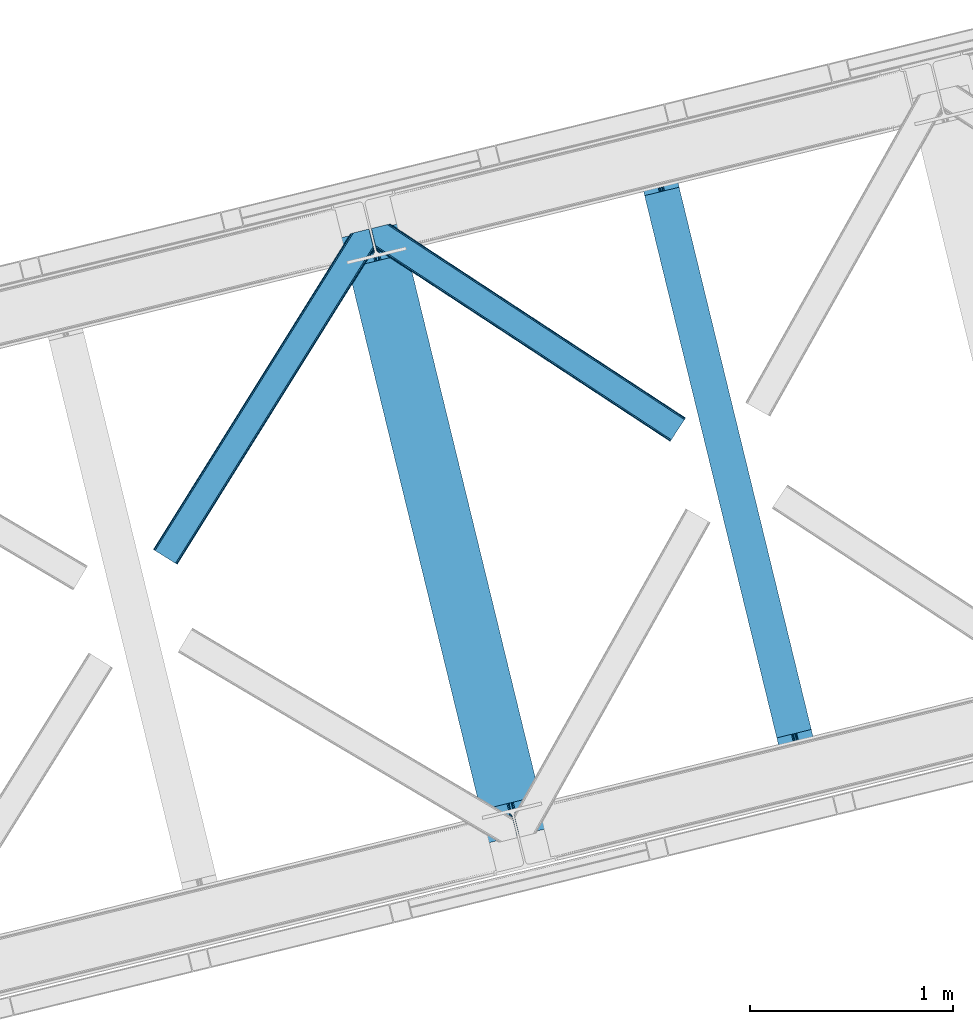
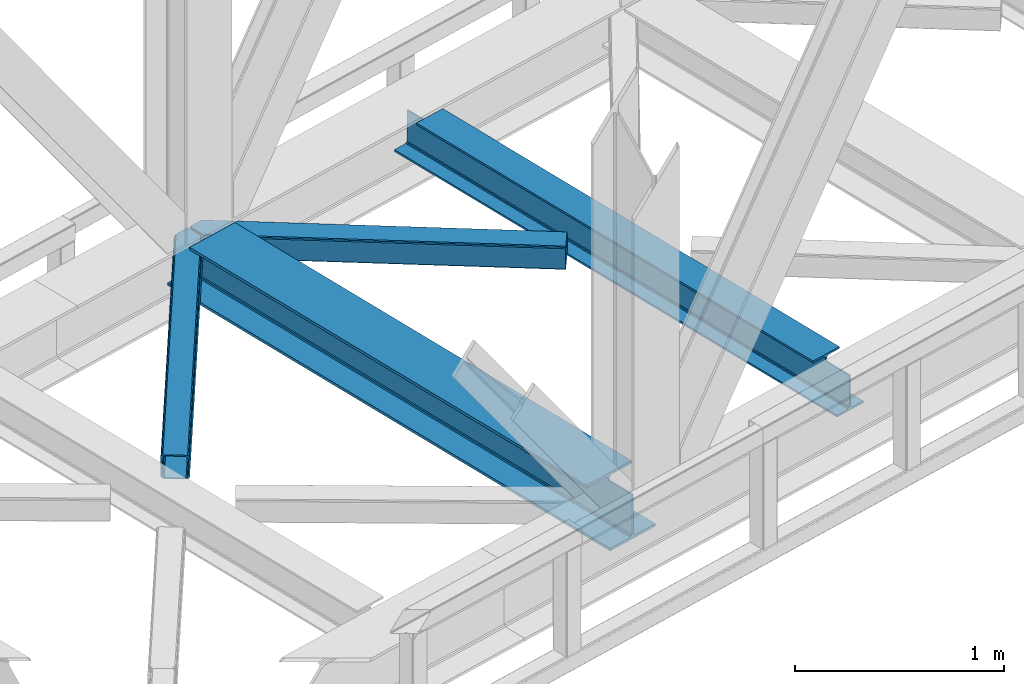
# One storey, part 77 of 92: 2 beams, 2 members.
"""IFC4 building model written with IfcOpenShell, lengths in millimetres."""

from ifc_helpers import new_model, entity, si_unit, converted_unit, derived_unit, direction, frame, origin, place, context, subcontext, project, spatial, triangles, polygons, material, type_object, element, save


model = new_model("IFC4")

# Units and contexts
model_context = context("Model", 3, precision=0.01, world=origin(), true_north=direction((6.12303176911189e-17, 1.0)))
plan_context = context("Plan", 3, precision=0.01, world=origin(), true_north=direction((6.12303176911189e-17, 1.0)))
body_context = subcontext(model_context, "Body", "Model", "MODEL_VIEW")
ifc_project = project(units=[si_unit("LENGTHUNIT", "METRE", prefix="MILLI"), si_unit("AREAUNIT", "SQUARE_METRE"), si_unit("VOLUMEUNIT", "CUBIC_METRE"), converted_unit("PLANEANGLEUNIT", "DEGREE", entity("IfcRatioMeasure", 0.0174532925199433), si_unit("PLANEANGLEUNIT", "RADIAN"), dimensions=[0, 0, 0, 0, 0, 0, 0]), si_unit("MASSUNIT", "GRAM", prefix="KILO"), derived_unit("MASSDENSITYUNIT", [(si_unit("MASSUNIT", "GRAM", prefix="KILO"), 1), (si_unit("LENGTHUNIT", "METRE"), -3)]), derived_unit("MOMENTOFINERTIAUNIT", [(si_unit("LENGTHUNIT", "METRE"), 4)]), si_unit("TIMEUNIT", "SECOND"), si_unit("FREQUENCYUNIT", "HERTZ"), si_unit("THERMODYNAMICTEMPERATUREUNIT", "DEGREE_CELSIUS"), derived_unit("THERMALTRANSMITTANCEUNIT", [(si_unit("MASSUNIT", "GRAM", prefix="KILO"), 1), (si_unit("THERMODYNAMICTEMPERATUREUNIT", "KELVIN"), -1), (si_unit("TIMEUNIT", "SECOND"), -3)]), derived_unit("VOLUMETRICFLOWRATEUNIT", [(si_unit("LENGTHUNIT", "METRE"), 3), (si_unit("TIMEUNIT", "SECOND"), -1)]), derived_unit("MASSFLOWRATEUNIT", [(si_unit("MASSUNIT", "GRAM", prefix="KILO"), 1), (si_unit("TIMEUNIT", "SECOND"), -1)]), derived_unit("ROTATIONALFREQUENCYUNIT", [(si_unit("TIMEUNIT", "SECOND"), -1)]), si_unit("ELECTRICCURRENTUNIT", "AMPERE"), si_unit("ELECTRICVOLTAGEUNIT", "VOLT"), si_unit("POWERUNIT", "WATT"), si_unit("FORCEUNIT", "NEWTON", prefix="KILO"), si_unit("ILLUMINANCEUNIT", "LUX"), si_unit("LUMINOUSFLUXUNIT", "LUMEN"), si_unit("LUMINOUSINTENSITYUNIT", "CANDELA"), derived_unit("USERDEFINED", [(si_unit("MASSUNIT", "GRAM", prefix="KILO"), -1), (si_unit("LENGTHUNIT", "METRE"), -2), (si_unit("TIMEUNIT", "SECOND"), 3), (si_unit("LUMINOUSFLUXUNIT", "LUMEN"), 1)]), derived_unit("LINEARVELOCITYUNIT", [(si_unit("LENGTHUNIT", "METRE"), 1), (si_unit("TIMEUNIT", "SECOND"), -1)]), si_unit("PRESSUREUNIT", "PASCAL"), derived_unit("USERDEFINED", [(si_unit("LENGTHUNIT", "METRE"), -2), (si_unit("MASSUNIT", "GRAM", prefix="KILO"), 1), (si_unit("TIMEUNIT", "SECOND"), -2)]), derived_unit("LINEARFORCEUNIT", [(si_unit("MASSUNIT", "GRAM", prefix="KILO"), 1), (si_unit("LENGTHUNIT", "METRE"), 1), (si_unit("TIMEUNIT", "SECOND"), -2), (si_unit("LENGTHUNIT", "METRE"), -1)]), derived_unit("PLANARFORCEUNIT", [(si_unit("MASSUNIT", "GRAM", prefix="KILO"), 1), (si_unit("LENGTHUNIT", "METRE"), 1), (si_unit("TIMEUNIT", "SECOND"), -2), (si_unit("LENGTHUNIT", "METRE"), -2)])], contexts=[model_context, plan_context])

# Site, building, storey
site_placement = place(None, origin())
site = spatial("IfcSite", under=ifc_project, at=site_placement, CompositionType="ELEMENT")
building_placement = place(site_placement, origin())
building = spatial("IfcBuilding", under=site, at=building_placement, CompositionType="ELEMENT")
storey_placement = place(building_placement, frame((0.0, 0.0, 15900.0)))
storey = spatial("IfcBuildingStorey", under=building, at=storey_placement, Name="05", CompositionType="ELEMENT", Elevation=15900.0)

# Beams
ifc_material = material(Name="Metal painted (White)")
beam_type = type_object("IfcBeamType", PredefinedType="BEAM")
beam_1_placement = place(storey_placement, frame((-11884.4, 14897.98, 3385.0)))
element("IfcBeam", 1, at=beam_1_placement, inside=storey, type_object=beam_type, material=ifc_material, ObjectType="Steel Beam", PredefinedType="BEAM", context=body_context, shape_type="Tessellation", body=[
    polygons([(1018.1664837833, 71.0478278971021, 15.4999999999986), (1018.1664837833, 71.0478278971021, 0.0), (291.465617442446, 3052.25531830421, 0.0), (291.465617442448, 3052.25531830421, 15.4999999999986), (894.779372399325, 40.970914087327, 15.4999999999986), (168.078506058474, 3022.17840449444, 15.4999999999986), (888.087028625373, 39.3395844888265, 16.8701684147941), (161.386162284522, 3020.54707489594, 16.8701684147941), (882.413533524757, 37.956610033654, 20.7720779386413), (155.712667183906, 3019.16410044077, 20.7720779386413), (878.622625296178, 37.0325360459184, 26.6116982174294), (151.921758955329, 3018.24002645303, 26.6116982174294), (877.291435352781, 36.7080444135029, 33.500000000001), (150.59056901193, 3017.91553482062, 33.500000000001), (140.875048430516, 3015.54727389071, 33.500000000001), (140.875048430518, 3015.54727389072, 259.000000000002), (150.590569011926, 3017.91553482062, 259.000000000002), (0.0, 2981.20749040711, 0.0), (0.0, 2981.20749040711, 15.4999999999986), (123.387111383964, 3011.28440421689, 15.4999999999986), (130.079455157922, 3012.91573381539, 16.8701684147963), (135.75295025854, 3014.29870827056, 20.7720779386413), (139.543858487119, 3015.2227822583, 26.6116982174294), (877.291435352779, 36.7080444135029, 259.000000000002), (867.575914771371, 34.3397834836014, 259.000000000002), (867.575914771369, 34.3397834836014, 33.500000000001), (866.24472482797, 34.0152918511859, 26.6116982174294), (862.453816599391, 33.0912178634502, 20.7720779386413), (856.780321498773, 31.70824340828, 16.8701684147963), (850.087977724817, 30.0769138097752, 15.4999999999986), (726.700866340853, 0.0, 15.4999999999986), (726.700866340851, 0.0, 0.0), (838.124523615903, 197.385937999177, 259.069791973884), (186.469722099962, 2870.72539801219, 259.000000000002), (186.693115201814, 2869.8089536072, 259.61730333112), (186.705504045441, 2869.75812937344, 266.500003008253), (837.979344808139, 197.981416001704, 266.500002998871), (837.979694928891, 197.97997969697, 260.000004007589), (828.499586345885, 194.645865944436, 259.006343171919), (828.276216326122, 195.562317481916, 259.61730333112), (828.263827482494, 195.613141715691, 266.500003008253), (176.989986719795, 2867.38985508742, 266.500002998871), (176.989636599043, 2867.39129139216, 260.000004007589), (176.844830940709, 2867.98534020595, 259.07612046749), (176.754201518552, 2868.35713708228, 259.000000000002), (839.310832678068, 198.30468544639, 273.388305639783), (843.101109266764, 199.231350618303, 279.227924098781), (848.774180214298, 200.616065081983, 283.129832400619), (855.466371895423, 202.248018612794, 284.500000377224), (978.853400583271, 232.325271667905, 284.500000138971), (978.85173077662, 232.332121736639, 299.999995328161), (687.386308679347, 161.283492472596, 299.999995890962), (687.387978485999, 161.276642403863, 284.500000701776), (810.775007173843, 191.353895458974, 284.500000463519), (817.467494069984, 192.984637925553, 283.129832461069), (823.141405718746, 194.365903570079, 279.227924137322), (826.93294050574, 195.287407219375, 273.388305663684), (175.658498849859, 2867.06658564273, 273.388305639783), (171.868222261163, 2866.13992047082, 279.227924098781), (166.195151313627, 2864.75520600715, 283.129832400619), (159.502959632495, 2863.12325247633, 284.500000377228), (36.1159309446555, 2833.04599942122, 284.500000138971), (36.117600751305, 2833.03914935249, 299.999995328161), (327.583022848578, 2904.08777861653, 299.999995890962), (327.58135304193, 2904.09462868526, 284.500000701776), (204.194324354075, 2874.01737563015, 284.500000463519), (197.501837457941, 2872.38663316357, 283.129832461069), (191.827925809183, 2871.00536751905, 279.227924137322), (188.036391022187, 2870.08386386975, 273.388305663684)], [[[1, 2, 3, 4]], [[5, 1, 4, 6]], [[7, 5, 6, 8]], [[9, 7, 8, 10]], [[11, 9, 10, 12]], [[13, 11, 12, 14]], [[15, 16, 17, 14, 12, 10, 8, 6, 4, 3, 18, 19, 20, 21, 22, 23]], [[13, 24, 25, 26, 27, 28, 29, 30, 31, 32, 2, 1, 5, 7, 9, 11]], [[2, 32, 18, 3]], [[32, 31, 19, 18]], [[31, 30, 20, 19]], [[27, 26, 15, 23]], [[28, 27, 23, 22]], [[29, 28, 22, 21]], [[30, 29, 21, 20]], [[33, 24, 13, 14, 17, 34, 35, 36, 37, 38]], [[25, 39, 40, 41, 42, 43, 44, 16, 15, 26]], [[39, 25, 24, 33]], [[45, 34, 17, 16]], [[41, 40, 38, 37, 46, 47, 48, 49, 50, 51, 52, 53, 54, 55, 56, 57]], [[42, 58, 59, 60, 61, 62, 63, 64, 65, 66, 67, 68, 69, 36, 35, 43]], [[46, 37, 36, 69]], [[47, 46, 69, 68]], [[48, 47, 68, 67]], [[49, 48, 67, 66]], [[50, 49, 66, 65]], [[51, 50, 65, 64]], [[52, 51, 64, 63]], [[53, 52, 63, 62]], [[54, 53, 62, 61]], [[55, 54, 61, 60]], [[56, 55, 60, 59]], [[57, 56, 59, 58]], [[41, 57, 58, 42]]], closed=False),
])
beam_2_placement = place(storey_placement, frame((-10424.65, 15253.81, 3441.0)))
element("IfcBeam", 2, at=beam_2_placement, inside=storey, type_object=beam_type, material=ifc_material, ObjectType="Steel Beam", PredefinedType="BEAM", context=body_context, shape_type="Tessellation", body=[
    polygons([(896.722476515612, 41.4445662733081, 11.000000000004), (896.722476515612, 41.4445662733081, 2.16573425859679e-12), (170.021610174759, 3022.65205668042, 2.16573425859679e-12), (170.021610174761, 3022.65205668042, 11.000000000004), (830.656936561991, 25.3403919499678, 11.000000000004), (103.956070221142, 3006.54788235708, 11.000000000004), (824.70818654069, 23.8903211957374, 12.2179274798217), (98.0073201998405, 3005.09781160285, 12.2179274798217), (819.665079784586, 22.6610105689194, 15.686291501017), (92.9642134437362, 3003.86850097603, 15.686291501017), (816.295383581404, 21.8396114687119, 20.8770650821657), (89.5945172405538, 3003.04710187582, 20.8770650821657), (815.112103631726, 21.5511744621206, 27.0000000000047), (88.4112372908744, 3002.75866486923, 27.0000000000047), (81.6103728838758, 3001.1008822183, 27.0000000000047), (81.6103728838779, 3001.1008822183, 203.000000000006), (88.4112372908766, 3002.75866486923, 203.000000000006), (2.16573425859679e-12, 2981.20749040711, 2.16573425859679e-12), (2.16573425859679e-12, 2981.20749040711, 10.9999999999997), (66.065539953615, 2997.31166473045, 11.000000000004), (72.0142899749205, 2998.76173548468, 12.2179274798217), (77.0573967310248, 2999.9910461115, 15.6862915010192), (80.4270929341964, 3000.81244521171, 20.8770650821657), (815.112103631729, 21.5511744621206, 203.000000000006), (808.31123922473, 19.8933918111876, 203.000000000006), (808.311239224726, 19.8933918111876, 27.0000000000047), (807.127959275046, 19.6049548045963, 20.8770650821657), (803.758263071877, 18.7835557043887, 15.6862915010192), (798.715156315772, 17.5542450775685, 12.2179274798217), (792.766406294465, 16.1041743233403, 11.000000000004), (726.700866340851, 0.0, 10.9999999999997), (726.700866340854, 0.0, 2.16573425859679e-12), (775.945201911954, 182.229070489523, 203.069792164282), (124.290390378911, 2855.5685280608, 203.000000000006), (124.513271168059, 2854.65418562637, 203.617301946336), (124.52618541258, 2854.60120565348, 217.000003693143), (775.79999866923, 182.824605273252, 217.000003676718), (775.800869277125, 182.821033832373, 204.00000679514), (769.234900758907, 180.199471824628, 203.006342981088), (769.012053092182, 181.113823838954, 203.617301946336), (768.999138847657, 181.166803811845, 217.000003693143), (117.725325591008, 2852.94340419208, 217.000003676718), (117.724454983115, 2852.94697563296, 204.00000679514), (117.580155394062, 2853.53894853353, 203.076120467494), (117.489525971921, 2853.91074540987, 203.000000000006), (776.983483393262, 183.112202246694, 223.122939328039), (780.352479801943, 183.936472070576, 228.313710402595), (785.395115205966, 185.167716295877, 231.782072735464), (791.343694076675, 186.618489150563, 232.999999602236), (857.409144942201, 202.723028934497, 232.999999283132), (857.40767160576, 202.729072911368, 243.999994005812), (687.386290701843, 161.283566114478, 243.999994827032), (687.38776403828, 161.277522137604, 233.000000104353), (753.453214903792, 177.382061921539, 232.999999785253), (759.402120032137, 178.831496389764, 231.782072861012), (764.445684539264, 180.058929212899, 228.313710479427), (767.816071449, 180.877494870328, 223.122939372324), (116.541840866975, 2852.65580721863, 223.122939328043), (113.172844458302, 2851.83153739476, 228.313710402595), (108.130209054278, 2850.60029316945, 231.782072735464), (102.181630183564, 2849.14952031477, 232.999999602236), (36.1161793180448, 2833.04498053083, 232.999999283128), (36.1176526544845, 2833.03893655396, 243.999994005812), (206.139033558403, 2874.48444335085, 243.999994827032), (206.137560221968, 2874.49048732773, 233.000000104357), (140.072109356447, 2858.38594754379, 232.999999785253), (134.12320422811, 2856.93651307556, 231.782072861012), (129.079639720982, 2855.70908025243, 228.313710479427), (125.709252811239, 2854.890514595, 223.12293937232)], [[[1, 2, 3, 4]], [[5, 1, 4, 6]], [[7, 5, 6, 8]], [[9, 7, 8, 10]], [[11, 9, 10, 12]], [[13, 11, 12, 14]], [[15, 16, 17, 14, 12, 10, 8, 6, 4, 3, 18, 19, 20, 21, 22, 23]], [[13, 24, 25, 26, 27, 28, 29, 30, 31, 32, 2, 1, 5, 7, 9, 11]], [[2, 32, 18, 3]], [[32, 31, 19, 18]], [[31, 30, 20, 19]], [[27, 26, 15, 23]], [[28, 27, 23, 22]], [[29, 28, 22, 21]], [[30, 29, 21, 20]], [[33, 24, 13, 14, 17, 34, 35, 36, 37, 38]], [[25, 39, 40, 41, 42, 43, 44, 16, 15, 26]], [[39, 25, 24, 33]], [[45, 34, 17, 16]], [[41, 40, 38, 37, 46, 47, 48, 49, 50, 51, 52, 53, 54, 55, 56, 57]], [[42, 58, 59, 60, 61, 62, 63, 64, 65, 66, 67, 68, 69, 36, 35, 43]], [[46, 37, 36, 69]], [[47, 46, 69, 68]], [[48, 47, 68, 67]], [[49, 48, 67, 66]], [[50, 49, 66, 65]], [[51, 50, 65, 64]], [[52, 51, 64, 63]], [[53, 52, 63, 62]], [[54, 53, 62, 61]], [[55, 54, 61, 60]], [[56, 55, 60, 59]], [[57, 56, 59, 58]], [[41, 57, 58, 42]]], closed=False),
])

# Members
member_type_1 = type_object("IfcMemberType", PredefinedType="BRACE")
member_1_placement = place(storey_placement, frame((-12809.64, 16269.34, 3510.0)))
element("IfcMember", 3, at=member_1_placement, inside=storey, type_object=member_type_1, ObjectType="Steel Horizontal Brace", PredefinedType="BRACE", context=body_context, shape_type="Tessellation", body=[
    triangles([(933.019793701173, 1535.69114685059, 0.0), (967.779299926759, 1393.09054870606, 0.0), (14.8479309082031, 64.8692962646492, 0.0), (103.918075561523, 9.26687622070313, 0.0), (928.802609252929, 1552.99009094238, 5.49966430664063), (928.943298339844, 1552.41570739746, 5.20782165527635), (930.802487182616, 1544.78594055176, 1.33247680664135), (971.996484375, 1375.79160461426, 5.49966430664063), (971.856958007813, 1376.36598815918, 5.20782165527635), (969.996606445313, 1383.99575500488, 1.33247680664135), (972.211587524414, 1375.53696899414, 5.85313110351854), (972.422039794921, 1375.28233337402, 6.20659790039281), (928.915393066407, 1553.56912536621, 5.74383544921875), (972.724346923827, 1375.53696899414, 6.35310058594041), (929.030502319336, 1554.17606506348, 5.9996337890625), (973.025491333008, 1375.79160461426, 6.49960327148438), (929.145611572265, 1554.78300476074, 6.25659484863354), (929.253744506836, 1555.36087646485, 6.49960327148438), (4.3520599365238, 71.4223846435543, 5.12526855468968), (1.13365173339844, 73.4315643310547, 10.8028289794929), (973.359191894531, 1630.84231567383, 10.8028289794929), (976.915951538085, 1631.70854187012, 6.49960327148438), (9.16804504394531, 68.4155914306648, 1.33247680664135), (971.506979370117, 1630.3900177002, 17.5000946044929), (0.0, 74.1361724853523, 17.5000946044929), (1081.10028991699, 1548.91592102051, 6.49960327148438), (1056.20762329101, 1651.03643188476, 6.49960327148438), (971.506979370117, 1630.3900177002, 122.500662231447), (0.0, 74.1361724853523, 122.500662231447), (973.359191894531, 1630.84231567383, 129.197927856447), (1.13365173339844, 73.4315643310547, 129.197927856447), (978.636776733398, 1632.12828369141, 134.874325561526), (4.3520599365238, 71.4223846435543, 134.874325561526), (986.530480957032, 1634.05258483887, 138.667117309571), (9.16804504394531, 68.4155914306648, 138.667117309571), (995.83921508789, 1636.32105102539, 139.999594116212), (14.8479309082031, 64.8692962646492, 139.999594116212), (118.762518310547, 0.0, 17.5000946044929), (117.632354736328, 0.705770874023074, 10.8028289794929), (1085.14190368652, 1551.24949951172, 10.9783996582046), (1087.41618347168, 1552.56337280274, 13.5003387451179), (109.597961425781, 5.7205810546875, 1.33247680664135), (114.413946533203, 2.71378784179615, 5.12526855468968), (1087.56966247559, 1551.93434143066, 17.5000946044929), (1081.77583007812, 1575.70149536133, 139.999594116212), (1063.00837097168, 1652.69447021484, 139.999594116212), (103.918075561523, 9.26687622070313, 139.999594116212), (1083.99313659668, 1566.60553894043, 138.667117309571), (109.597961425781, 5.7205810546875, 138.667117309571), (1085.8720916748, 1558.8955444336, 134.874325561526), (114.413946533203, 2.71378784179615, 134.874325561526), (1087.12782897949, 1553.7435333252, 129.197927856447), (117.632354736328, 0.705770874023074, 129.197927856447), (1087.56966247559, 1551.93434143066, 122.500662231447), (118.762518310547, 0.0, 122.500662231447), (1082.53973693848, 1566.77297058106, 12.1260040283232), (1083.96406860352, 1566.72297363281, 13.5003387451179), (1077.85048828125, 1569.98440246582, 8.3320495605476), (1074.64952087402, 1577.50022277832, 6.99957275390625), (1056.69596557617, 1651.1561920166, 6.99957275390625), (1005.57234191895, 1638.6941619873, 6.99957275390625), (20.7836151123047, 61.1613830566403, 6.99957275390625), (97.9789031982418, 12.9736267089847, 6.99957275390625), (108.474774169921, 6.42053833007776, 12.1260040283232), (111.693182373047, 4.4113586425774, 17.8035644531265), (1084.81052856445, 1563.24992980957, 17.8035644531265), (103.6587890625, 9.42733154296911, 8.3320495605476), (1085.25236206055, 1561.44073791504, 24.4996673583992), (112.822183227539, 3.70675048828161, 24.4996673583992), (983.092318725587, 1633.21426391602, 17.8035644531265), (981.240106201172, 1632.76312866211, 24.4996673583992), (7.06817321777271, 69.7236511230476, 17.8035644531265), (5.93917236328161, 70.4294219970707, 24.4996673583992), (988.369903564453, 1634.50139465332, 12.1260040283232), (10.2865814208981, 67.7144714355472, 12.1260040283232), (996.263607788085, 1636.42569580078, 8.3320495605476), (15.1025665283196, 64.7088409423832, 8.3320495605476), (981.240106201172, 1632.76312866211, 115.501089477541), (5.93917236328161, 70.4294219970707, 115.501089477541), (996.263607788085, 1636.42569580078, 131.667544555665), (1005.57234191895, 1638.6941619873, 133.000021362306), (1063.00837097168, 1652.69447021484, 133.000021362306), (988.369903564453, 1634.50139465332, 127.87475280762), (983.092318725587, 1633.21426391602, 122.196029663086), (20.7836151123047, 61.1613830566403, 133.000021362306), (15.1025665283196, 64.7088409423832, 131.667544555665), (10.2865814208981, 67.7144714355472, 127.87475280762), (7.06817321777271, 69.7236511230476, 122.196029663086), (108.474774169921, 6.42053833007776, 127.87475280762), (111.693182373047, 4.4113586425774, 122.196029663086), (112.822183227539, 3.70675048828161, 115.501089477541), (97.9789031982418, 12.9736267089847, 133.000021362306), (103.6587890625, 9.42733154296911, 131.667544555665), (1085.25236206055, 1561.44073791504, 115.501089477541), (1084.81052856445, 1563.24992980957, 122.196029663086), (1083.55479125976, 1568.40194091797, 127.87475280762), (1081.67583618164, 1576.11309814453, 131.667544555665), (1079.45852966309, 1585.2078918457, 133.000021362306)], [[1, 2, 3], [4, 3, 2], [1, 5, 2], [6, 5, 1], [1, 7, 6], [2, 5, 8], [8, 9, 2], [10, 2, 9], [11, 8, 5], [12, 11, 13], [14, 12, 15], [16, 14, 17], [17, 18, 16], [15, 17, 14], [13, 15, 12], [5, 13, 11], [17, 19, 18], [19, 17, 15], [13, 19, 15], [19, 13, 5], [5, 6, 19], [20, 21, 18], [18, 19, 20], [21, 22, 18], [19, 6, 7], [7, 1, 23], [3, 23, 1], [7, 23, 19], [24, 21, 20], [20, 25, 24], [18, 26, 16], [26, 18, 22], [27, 26, 22], [28, 24, 29], [25, 29, 24], [30, 28, 31], [29, 31, 28], [32, 30, 33], [31, 33, 30], [34, 32, 35], [33, 35, 32], [36, 34, 37], [35, 37, 34], [38, 39, 40], [40, 41, 38], [42, 10, 9], [39, 12, 16], [16, 40, 39], [16, 26, 40], [9, 39, 43], [9, 12, 39], [9, 43, 42], [2, 10, 4], [42, 4, 10], [41, 44, 38], [45, 36, 37], [36, 45, 46], [37, 47, 45], [48, 45, 47], [47, 49, 48], [50, 48, 49], [49, 51, 50], [52, 50, 51], [51, 53, 52], [54, 52, 53], [53, 55, 54], [44, 54, 55], [55, 38, 44], [56, 40, 26], [41, 40, 56], [56, 57, 41], [58, 26, 59], [26, 58, 56], [60, 59, 26], [59, 61, 62], [61, 59, 60], [62, 63, 59], [64, 65, 66], [66, 57, 64], [58, 59, 63], [63, 67, 58], [56, 58, 67], [67, 64, 56], [57, 56, 64], [68, 66, 65], [65, 69, 68], [70, 71, 72], [73, 72, 71], [74, 70, 75], [72, 75, 70], [76, 74, 77], [75, 77, 74], [61, 76, 62], [77, 62, 76], [71, 78, 73], [79, 73, 78], [34, 36, 80], [46, 81, 36], [81, 46, 82], [81, 80, 36], [83, 34, 80], [83, 32, 34], [32, 84, 30], [84, 32, 83], [28, 84, 78], [84, 28, 30], [61, 22, 76], [70, 74, 22], [74, 76, 22], [61, 60, 22], [71, 70, 24], [21, 24, 70], [28, 71, 24], [71, 28, 78], [70, 22, 21], [80, 81, 85], [85, 86, 80], [83, 80, 86], [86, 87, 83], [84, 83, 87], [87, 88, 84], [78, 84, 88], [88, 79, 78], [53, 89, 90], [91, 38, 55], [53, 90, 55], [53, 51, 89], [90, 91, 55], [89, 51, 49], [92, 47, 37], [47, 93, 49], [93, 47, 92], [93, 89, 49], [39, 64, 43], [69, 38, 91], [38, 65, 39], [65, 38, 69], [39, 65, 64], [4, 63, 3], [42, 43, 64], [64, 67, 42], [67, 63, 4], [4, 42, 67], [87, 35, 33], [37, 85, 92], [37, 86, 85], [86, 37, 35], [87, 86, 35], [79, 29, 25], [31, 88, 87], [33, 31, 87], [88, 31, 29], [79, 88, 29], [23, 75, 19], [3, 63, 62], [62, 77, 3], [77, 75, 23], [23, 3, 77], [20, 19, 75], [25, 73, 79], [72, 25, 20], [25, 72, 73], [72, 20, 75], [66, 41, 57], [54, 44, 68], [44, 66, 68], [68, 94, 54], [44, 41, 66], [95, 54, 94], [52, 54, 95], [50, 95, 96], [95, 50, 52], [96, 48, 50], [97, 48, 96], [97, 98, 45], [97, 45, 48], [98, 46, 45], [98, 82, 46], [81, 98, 85], [81, 82, 98], [92, 85, 98], [95, 94, 90], [91, 90, 94], [96, 95, 89], [90, 89, 95], [97, 96, 93], [89, 93, 96], [98, 97, 92], [93, 92, 97], [94, 68, 91], [69, 91, 68]]),
])
member_type_2 = type_object("IfcMemberType", PredefinedType="BRACE")
member_2_placement = place(storey_placement, frame((-11734.97, 16875.1, 3510.0)))
element("IfcMember", 4, at=member_2_placement, inside=storey, type_object=member_type_2, ObjectType="Steel Horizontal Brace", PredefinedType="BRACE", context=body_context, shape_type="Tessellation", body=[
    triangles([(1548.83336791992, 117.035879516599, 122.500662231447), (1548.83336791992, 117.035879516599, 17.5000946044929), (93.3036071777333, 1072.51941833496, 122.500662231447), (93.3036071777333, 1072.51941833496, 17.5000946044929), (1539.23046569824, 102.406539916992, 139.999594116212), (1542.90582275391, 108.005035400391, 138.667117309571), (78.9486694335938, 1069.01963195801, 138.667117309571), (70.0515380859379, 1066.85115966797, 139.999594116212), (1546.02423706055, 112.751257324217, 134.874325561526), (86.4947204589844, 1070.85905456543, 134.874325561526), (1548.10434265137, 115.921994018554, 129.197927856447), (91.5327850341801, 1072.0880493164, 129.197927856447), (18.1488922119133, 975.321862792967, 139.999594116212), (0.0, 1049.77545776367, 139.999594116212), (1481.61188964844, 14.6293395996072, 139.999594116212), (1472.00782470703, 0.0, 122.500662231447), (1472.73684997558, 1.11388549804542, 129.197927856447), (24.2241027832024, 950.400128173827, 122.500662231447), (23.7613403320302, 952.296524047852, 129.197927856447), (1474.82160644531, 4.28578491210646, 134.874325561526), (22.4439788818363, 957.699682617185, 134.874325561526), (1477.93536987305, 9.03084411620875, 138.667117309571), (20.4731689453129, 965.784072875977, 138.667117309571), (1472.00782470703, 0.0, 17.5000946044929), (24.2241027832024, 950.400128173827, 17.5000946044929), (1548.10434265137, 115.921994018554, 10.8028289794929), (91.1804809570313, 1072.00200805664, 10.8679412841811), (163.772561645508, 1023.9595916748, 9.52034912109593), (1546.02423706055, 112.751257324217, 5.12526855468968), (166.108465576172, 1018.59829101562, 5.12526855468968), (165.189916992187, 1022.36666564941, 8.52041015625218), (164.479495239257, 1023.16196594238, 9.02037963867406), (90.7467864990231, 1071.89620056152, 9.52034912109593), (1542.90582275391, 108.005035400391, 1.33247680664135), (168.079275512695, 1010.51273803711, 1.33247680664135), (1539.23046569824, 102.406539916992, 0.0), (170.40471496582, 1000.97611083984, 0.0), (198.048376464843, 887.571405029295, 0.0), (164.338806152344, 879.354464721677, 0.0), (1481.61188964844, 14.6293395996072, 0.0), (169.43733215332, 1003.19574279785, 9.13665161133031), (168.980383300781, 1004.20614624023, 9.44360961914208), (169.896606445313, 1002.17603759766, 8.82736816406396), (170.358206176757, 1001.166796875, 8.52041015625218), (72.7711395263668, 1067.51507263184, 9.52034912109593), (168.468786621093, 1004.69565124511, 9.52034912109593), (172.834799194336, 991.006951904295, 6.99957275390625), (198.048376464843, 887.571405029295, 6.99957275390625), (1539.0665222168, 102.153067016599, 8.3320495605476), (1542.18028564453, 106.899288940429, 12.1260040283232), (77.1906372070316, 1068.59175109863, 12.1260040283232), (1544.26504211426, 110.07118835449, 17.8035644531265), (82.2333526611328, 1069.82074584961, 17.8035644531265), (1544.99406738281, 111.183911132812, 24.4996673583992), (84.0041748046879, 1070.25327758789, 24.4996673583992), (1535.39116516113, 96.5545715332009, 6.99957275390625), (173.638238525391, 881.621768188474, 6.99957275390625), (1485.45119018555, 20.4813079833984, 6.99957275390625), (164.935281372071, 879.499804687497, 8.82504272460938), (161.614553833007, 878.690551757813, 9.52034912109593), (155.438186645508, 877.184829711914, 1.33247680664135), (147.892135620117, 875.345407104491, 5.12526855468968), (143.640069580078, 874.309423828123, 9.52034912109593), (30.6016204833977, 948.074688720702, 10.8702667236357), (24.2136383056641, 950.43966064453, 16.5199218750022), (1472.73684997558, 1.11388549804542, 10.8028289794929), (1474.82160644531, 4.28578491210646, 5.12526855468968), (32.1329223632802, 947.51076965332, 9.52034912109593), (1477.93536987305, 9.03084411620875, 1.33247680664135), (27.4366973876949, 966.774710083006, 9.52034912109593), (25.3949615478505, 964.131848144531, 12.1260040283232), (21.1254547119133, 963.109817504883, 16.5199218750022), (1476.5808013916, 6.96585388183303, 17.8035644531265), (1478.66090698242, 10.1365905761704, 12.1260040283232), (21.2382385253895, 962.647055053709, 17.8686767578147), (21.7940185546868, 960.368124389646, 24.4996673583992), (1481.77467041016, 14.8828125, 8.3320495605476), (1475.84712524414, 5.85196838378761, 24.4996673583992), (1544.99406738281, 111.183911132812, 115.501089477541), (84.0041748046879, 1070.25327758789, 115.501089477541), (77.1906372070316, 1068.59175109863, 127.87475280762), (69.6492370605465, 1066.75349121094, 131.667544555665), (82.2333526611328, 1069.82074584961, 122.196029663086), (60.7474548339833, 1064.58385620117, 133.000021362306), (0.0, 1049.77545776367, 133.000021362306), (1544.26504211426, 110.07118835449, 122.196029663086), (1542.18028564453, 106.899288940429, 127.87475280762), (1539.0665222168, 102.153067016599, 131.667544555665), (1535.39116516113, 96.5545715332009, 133.000021362306), (1478.66090698242, 10.1365905761704, 127.87475280762), (1485.45119018555, 20.4813079833984, 133.000021362306), (1481.77467041016, 14.8828125, 131.667544555665), (1475.84712524414, 5.85196838378761, 115.501089477541), (1476.5808013916, 6.96585388183303, 122.196029663086), (21.3312561035145, 962.265682983398, 122.196029663086), (20.0138946533207, 967.667678833008, 127.87475280762), (21.7940185546868, 960.368124389646, 115.501089477541), (18.0430847167972, 975.753231811523, 131.667544555665), (15.7188079833977, 985.289859008786, 133.000021362306)], [[1, 2, 3], [4, 3, 2], [5, 6, 7], [7, 8, 5], [6, 9, 10], [10, 7, 6], [9, 11, 12], [12, 10, 9], [11, 1, 3], [3, 12, 11], [8, 13, 5], [8, 14, 13], [15, 5, 13], [16, 17, 18], [19, 18, 17], [17, 20, 19], [21, 19, 20], [20, 22, 21], [23, 21, 22], [22, 15, 23], [13, 23, 15], [24, 16, 18], [18, 25, 24], [26, 27, 4], [27, 26, 28], [26, 29, 30], [30, 31, 26], [26, 31, 32], [32, 28, 26], [28, 33, 27], [29, 34, 35], [35, 30, 29], [34, 36, 37], [37, 35, 34], [4, 2, 26], [38, 37, 36], [39, 38, 40], [36, 40, 38], [32, 41, 42], [31, 43, 41], [31, 44, 43], [45, 33, 28], [28, 46, 45], [44, 35, 37], [30, 35, 44], [44, 31, 30], [47, 44, 37], [37, 38, 47], [48, 47, 38], [49, 44, 47], [43, 49, 41], [43, 44, 49], [42, 41, 49], [50, 51, 46], [46, 49, 50], [51, 45, 46], [50, 52, 53], [53, 51, 50], [52, 54, 55], [55, 53, 52], [47, 56, 49], [48, 57, 58], [47, 48, 56], [58, 56, 48], [59, 57, 39], [60, 39, 61], [61, 62, 60], [38, 57, 48], [57, 38, 39], [62, 63, 60], [39, 60, 59], [24, 25, 64], [25, 65, 64], [66, 64, 63], [63, 67, 66], [63, 62, 67], [64, 68, 63], [40, 69, 39], [61, 39, 69], [69, 67, 61], [62, 61, 67], [64, 66, 24], [70, 64, 71], [64, 70, 68], [65, 71, 64], [72, 71, 65], [68, 70, 60], [60, 63, 68], [73, 74, 71], [71, 72, 73], [73, 75, 76], [77, 58, 57], [74, 77, 59], [59, 60, 74], [74, 60, 71], [70, 71, 60], [57, 59, 77], [76, 78, 73], [72, 75, 73], [54, 79, 80], [80, 55, 54], [81, 82, 7], [10, 81, 7], [10, 12, 83], [81, 10, 83], [83, 12, 3], [82, 8, 7], [14, 84, 85], [14, 8, 84], [82, 84, 8], [83, 3, 80], [55, 4, 53], [3, 55, 80], [4, 27, 53], [3, 4, 55], [33, 53, 27], [51, 53, 33], [45, 51, 33], [79, 86, 80], [83, 80, 86], [86, 87, 83], [81, 83, 87], [87, 88, 81], [82, 81, 88], [88, 89, 82], [84, 82, 89], [11, 87, 86], [79, 2, 1], [11, 86, 1], [11, 9, 87], [86, 79, 1], [87, 9, 6], [89, 5, 15], [5, 88, 6], [88, 5, 89], [88, 87, 6], [26, 50, 29], [54, 2, 79], [2, 52, 26], [52, 2, 54], [26, 52, 50], [36, 56, 40], [34, 29, 50], [50, 49, 34], [49, 56, 36], [36, 34, 49], [90, 22, 20], [15, 91, 89], [15, 92, 91], [92, 15, 22], [90, 92, 22], [93, 16, 24], [17, 94, 90], [20, 17, 90], [94, 17, 16], [93, 94, 16], [69, 74, 67], [40, 56, 58], [58, 77, 40], [77, 74, 69], [69, 40, 77], [66, 67, 74], [24, 78, 93], [73, 24, 66], [24, 73, 78], [73, 66, 74], [95, 21, 96], [97, 76, 18], [19, 95, 18], [95, 19, 21], [95, 97, 18], [76, 25, 18], [75, 72, 65], [65, 25, 75], [76, 75, 25], [98, 23, 13], [14, 99, 13], [85, 99, 14], [98, 96, 23], [23, 96, 21], [99, 98, 13], [99, 84, 89], [84, 99, 85], [89, 91, 99], [91, 92, 98], [98, 99, 91], [92, 90, 96], [96, 98, 92], [90, 94, 95], [95, 96, 90], [94, 93, 97], [97, 95, 94], [93, 78, 76], [76, 97, 93]]),
])

save(model, "model.ifc")
